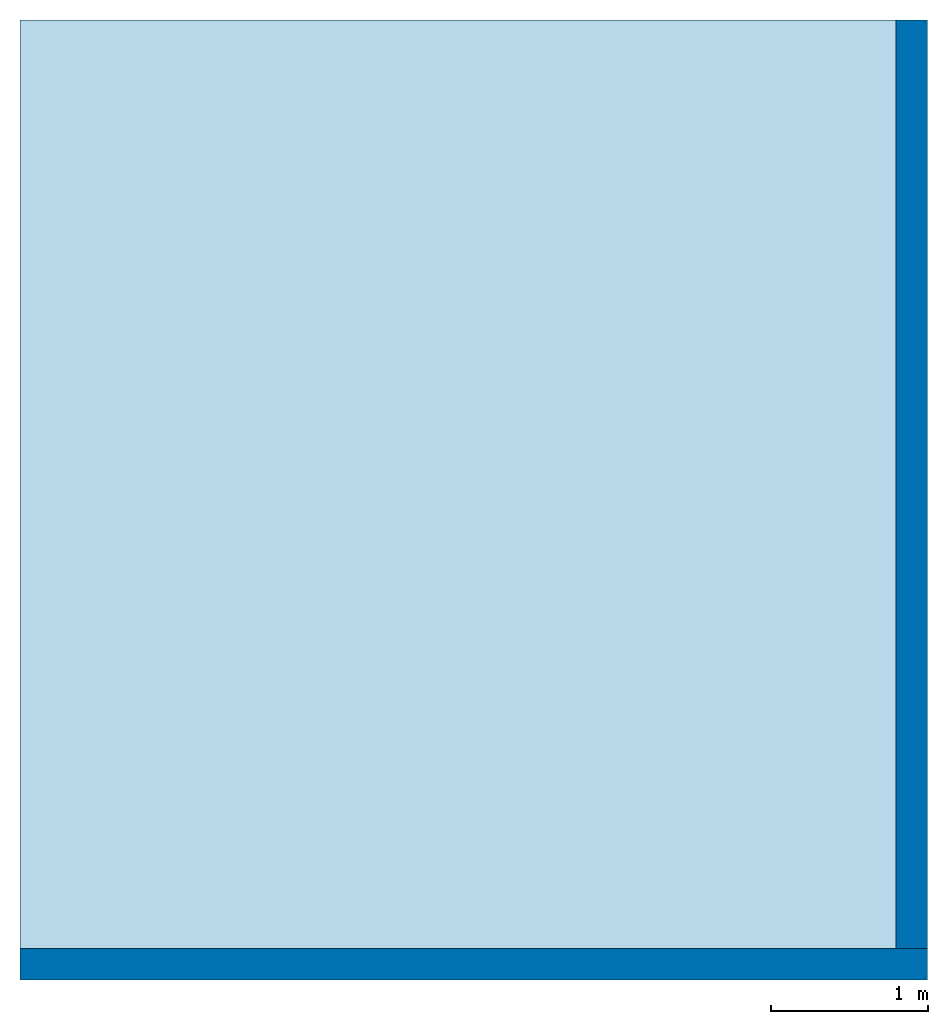
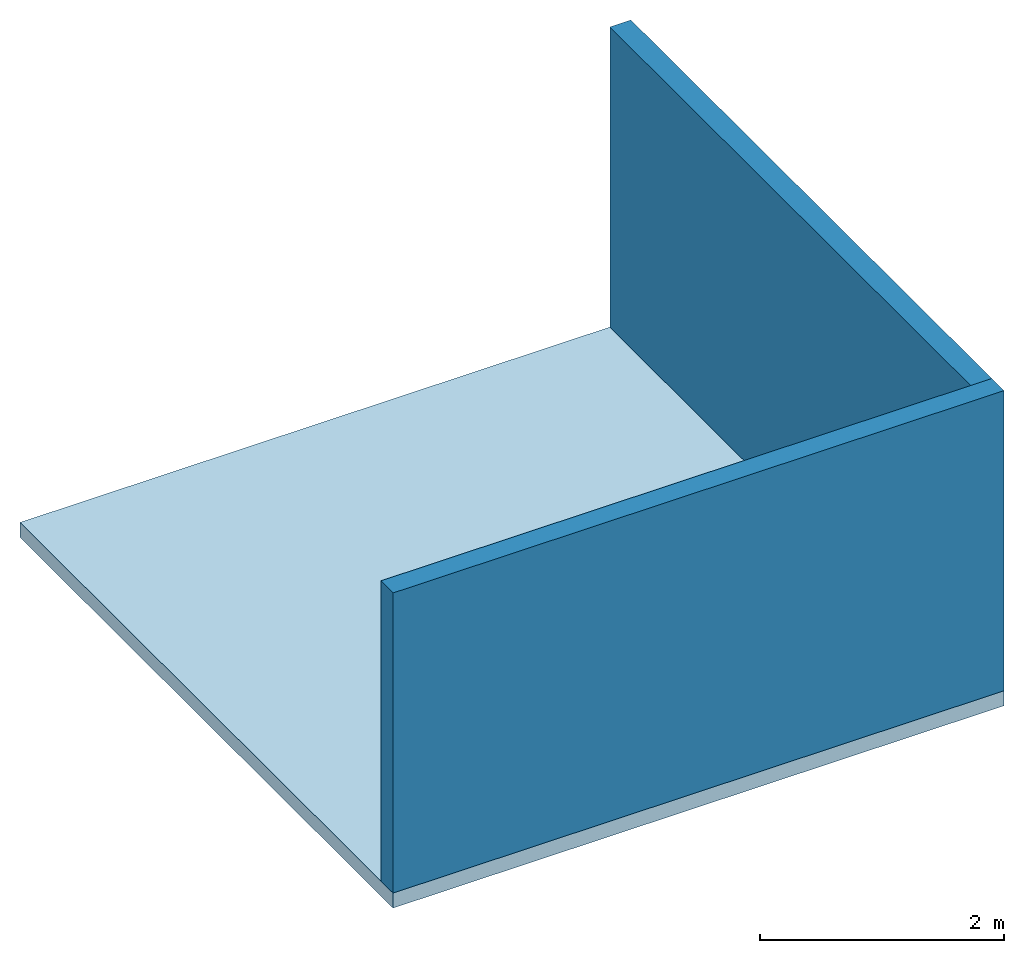
# One storey: 2 walls, 1 slab.
"""IFC4 building model written with IfcOpenShell, lengths in metres."""

from ifc_helpers import new_model, entity, si_unit, converted_unit, frame, origin_with_axes, origin_2d_with_axis, place, context, subcontext, project, spatial, line, indexed_curve, outline, extrude, material, layer, layer_set, layer_usage, type_object, element, save


model = new_model("IFC4")

# Units and contexts
model_context = context("Model", 3, precision=1e-05, world=origin_with_axes())
plan_context = context("Plan", 2, precision=1e-05, world=origin_2d_with_axis())
body_context = subcontext(model_context, "Body", "Model", "MODEL_VIEW")
ifc_project = project(units=[converted_unit("PLANEANGLEUNIT", "degree", entity("IfcReal", 0.0174532925199433), si_unit("PLANEANGLEUNIT", "RADIAN"), dimensions=[0, 0, 0, 0, 0, 0, 0]), si_unit("AREAUNIT", "SQUARE_METRE"), si_unit("VOLUMEUNIT", "CUBIC_METRE"), si_unit("LENGTHUNIT", "METRE")], contexts=[model_context, plan_context])

# Site, building, storey
site_placement = place(None, origin_with_axes())
site = spatial("IfcSite", under=ifc_project, at=site_placement)
building_placement = place(site_placement, origin_with_axes())
building = spatial("IfcBuilding", under=site, at=building_placement, Name="Building")
storey_placement = place(building_placement, origin_with_axes())
storey = spatial("IfcBuildingStorey", under=building, at=storey_placement, Name="Storey")

# Slab
ifc_material = material()
ifc_layer_1 = layer(ifc_material, 0.150000005960464)
ifc_layer_set_1 = layer_set([ifc_layer_1])
ifc_layer_usage_1 = layer_usage(ifc_layer_set_1, "AXIS3", "POSITIVE", 0.0)
slab_type = type_object("IfcSlabType", Name="slab", PredefinedType="FLOOR", material=ifc_layer_set_1)
slab_placement = place(storey_placement, frame((0.0, 0.0, -0.150000005960464), z_axis=(0.0, 0.0, 1.0), x_axis=(1.0, 0.0, 0.0)))
element("IfcSlab", 1, at=slab_placement, inside=storey, type_object=slab_type, material=ifc_layer_usage_1, Name="Slab", context=body_context, shape_type="SweptSolid", body=[
    extrude(outline(indexed_curve([(0.0, 0.0), (5.77615118026733, 0.0), (5.77615118026733, 6.10984325408936), (0.0, 6.10984325408936)], segments=[line(3, 2), line(2, 1), line(1, 4), line(4, 3)], self_intersect=False)), None, (0.0, 0.0, 1.0), 0.150000005960464),
])

# Walls
ifc_layer_2 = layer(ifc_material, 0.200000002980232)
ifc_layer_set_2 = layer_set([ifc_layer_2])
ifc_layer_usage_2 = layer_usage(ifc_layer_set_2, "AXIS2", "POSITIVE", 0.0)
wall_type = type_object("IfcWallType", Name="wall200", PredefinedType="SOLIDWALL", material=ifc_layer_set_2)
wall_1_placement = place(storey_placement, origin_with_axes())
element("IfcWall", 2, at=wall_1_placement, inside=storey, type_object=wall_type, material=ifc_layer_usage_2, Name="Wall", context=body_context, shape_type="SweptSolid", body=[
    extrude(outline(indexed_curve([(0.0, 0.0), (0.0, 0.200000002980232), (5.77615115099498, 0.200000002980232), (5.77615115099498, 0.0), (0.0, 0.0)], self_intersect=False)), origin_with_axes(), (0.0, 0.0, 1.0), 3.0),
])
ifc_layer_usage_3 = layer_usage(ifc_layer_set_2, "AXIS2", "POSITIVE", 0.0)
wall_2_placement = place(storey_placement, frame((5.77615118026733, 0.200000002980232, 0.0), z_axis=(0.0, 0.0, 1.0), x_axis=(7.54979012640431e-08, 0.999999999999997, 0.0)))
element("IfcWall", 3, at=wall_2_placement, inside=storey, type_object=wall_type, material=ifc_layer_usage_3, Name="Wall", context=body_context, shape_type="SweptSolid", body=[
    extrude(outline(indexed_curve([(0.0, 0.0), (0.0, 0.200000002980232), (5.90984352227398, 0.200000002980232), (5.90984352227398, 0.0), (0.0, 0.0)], self_intersect=False)), origin_with_axes(), (0.0, 0.0, 1.0), 3.0),
])

save(model, "model.ifc")
